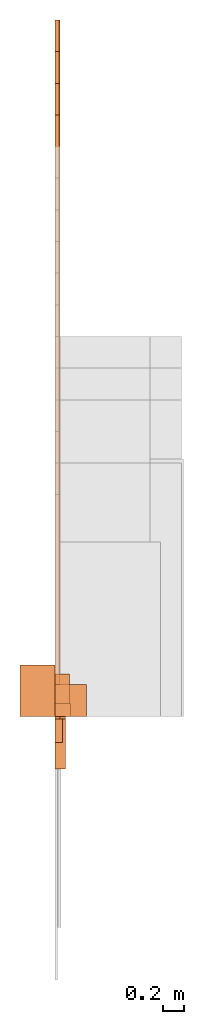
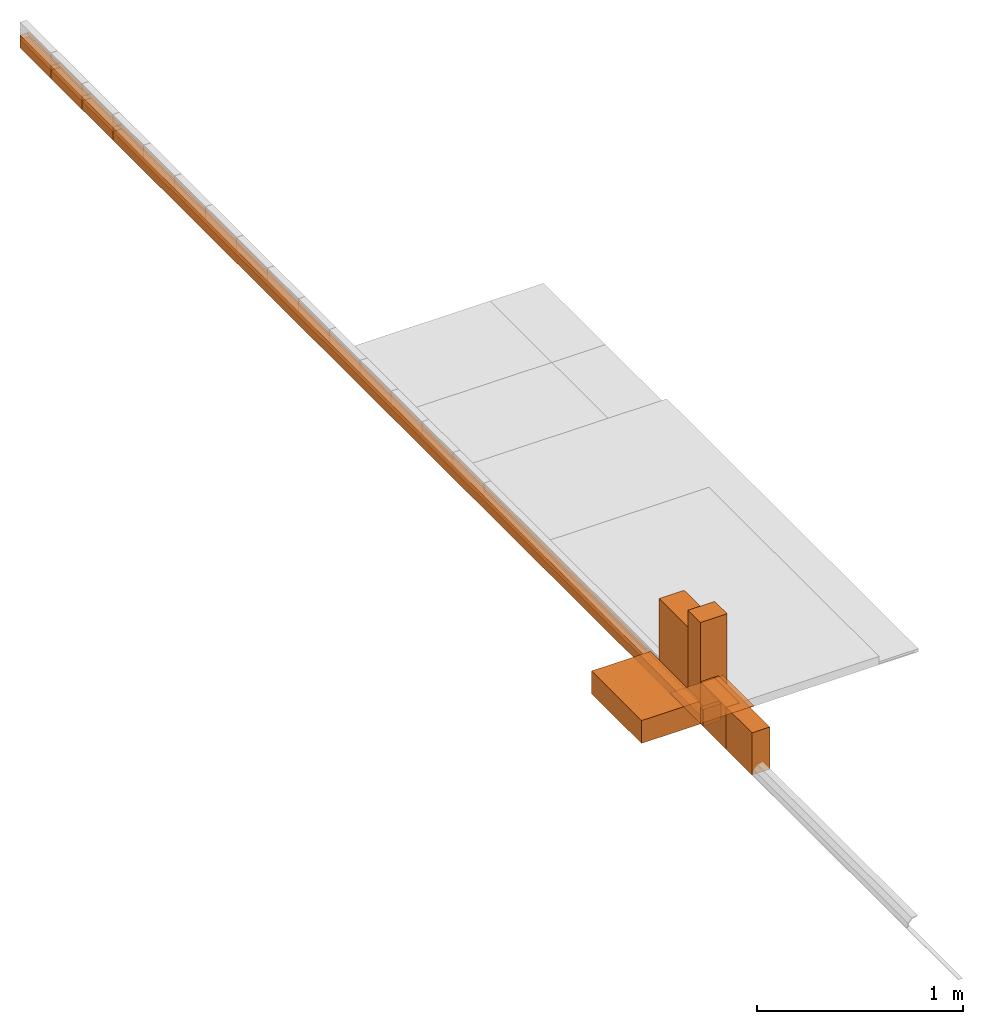
# Not in any storey, part 5 of 5: 22 proxies.
"""IFC4 model written with IfcOpenShell, lengths in metres."""

from ifc_helpers import new_model, entity, si_unit, converted_unit, direction, origin_with_axes, place, context, subcontext, project, faceted_brep, element, save


model = new_model("IFC4")

# Units and contexts
model_context = context("Model", 3, precision=1e-05, world=origin_with_axes(), true_north=direction((0.0, 1.0)))
body_context = subcontext(model_context, "Body", "Model", "MODEL_VIEW")
ifc_project = project(units=[si_unit("LENGTHUNIT", "METRE"), si_unit("AREAUNIT", "SQUARE_METRE"), si_unit("VOLUMEUNIT", "CUBIC_METRE"), converted_unit("PLANEANGLEUNIT", "DEGREE", entity("IfcPlaneAngleMeasure", 0.017453292519943295), si_unit("PLANEANGLEUNIT", "RADIAN"), dimensions=[0, 0, 0, 0, 0, 0, 0])], contexts=[model_context])

# Proxies
proxy_1_placement = place(None, origin_with_axes())
element("IfcBuildingElementProxy", 1, at=proxy_1_placement, Name="Timber 38x76x5700", context=body_context, shape_type="Brep", body=[
    faceted_brep([(0.038, 0.0, 0.0), (0.038, 0.0, 0.076), (0.0, 0.0, 0.076), (0.0, 0.0, 0.0), (0.038, 5.7, 0.0), (0.038, 5.7, 0.076), (0.038, 0.0, 0.076), (0.038, 0.0, 0.0), (0.0, 5.7, 0.0), (0.0, 5.7, 0.076), (0.038, 5.7, 0.076), (0.038, 5.7, 0.0), (0.0, 0.0, 0.0), (0.0, 0.0, 0.076), (0.0, 5.7, 0.076), (0.0, 5.7, 0.0), (0.0, 5.7, 0.0), (0.038, 5.7, 0.0), (0.038, 0.0, 0.0), (0.0, 0.0, 0.0), (0.0, 0.0, 0.076), (0.038, 0.0, 0.076), (0.038, 5.7, 0.076), (0.0, 5.7, 0.076)], [[[0, 1, 2, 3]], [[4, 5, 6, 7]], [[8, 9, 10, 11]], [[12, 13, 14, 15]], [[16, 17, 18, 19]], [[20, 21, 22, 23]]]),
])
proxy_2_placement = place(None, origin_with_axes())
element("IfcBuildingElementProxy", 2, at=proxy_2_placement, Name="Timber 38x76x6000", context=body_context, shape_type="Brep", body=[
    faceted_brep([(0.0, 6.0, 0.0), (0.0, 6.0, 0.076), (0.038, 6.0, 0.076), (0.038, 6.0, 0.0), (0.038, 6.0, 0.0), (0.038, 6.0, 0.076), (0.038, 0.0, 0.076), (0.038, 0.0, 0.0), (0.038, 0.0, 0.0), (0.038, 0.0, 0.076), (0.0, 0.0, 0.076), (0.0, 0.0, 0.0), (0.0, 0.0, 0.0), (0.0, 0.0, 0.076), (0.0, 6.0, 0.076), (0.0, 6.0, 0.0), (0.038, 0.0, 0.0), (0.0, 0.0, 0.0), (0.0, 6.0, 0.0), (0.038, 6.0, 0.0), (0.038, 6.0, 0.076), (0.0, 6.0, 0.076), (0.0, 0.0, 0.076), (0.038, 0.0, 0.076)], [[[0, 1, 2, 3]], [[4, 5, 6, 7]], [[8, 9, 10, 11]], [[12, 13, 14, 15]], [[16, 17, 18, 19]], [[20, 21, 22, 23]]]),
])
proxy_3_placement = place(None, origin_with_axes())
element("IfcBuildingElementProxy", 3, at=proxy_3_placement, Name="Timber 38x76x6300", context=body_context, shape_type="Brep", body=[
    faceted_brep([(0.038, 0.0, 0.0), (0.038, 0.0, 0.076), (0.0, 0.0, 0.076), (0.0, 0.0, 0.0), (0.038, 6.3, 0.0), (0.038, 6.3, 0.076), (0.038, 0.0, 0.076), (0.038, 0.0, 0.0), (0.0, 6.3, 0.0), (0.0, 6.3, 0.076), (0.038, 6.3, 0.076), (0.038, 6.3, 0.0), (0.0, 0.0, 0.0), (0.0, 0.0, 0.076), (0.0, 6.3, 0.076), (0.0, 6.3, 0.0), (0.0, 6.3, 0.0), (0.038, 6.3, 0.0), (0.038, 0.0, 0.0), (0.0, 0.0, 0.0), (0.0, 0.0, 0.076), (0.038, 0.0, 0.076), (0.038, 6.3, 0.076), (0.0, 6.3, 0.076)], [[[0, 1, 2, 3]], [[4, 5, 6, 7]], [[8, 9, 10, 11]], [[12, 13, 14, 15]], [[16, 17, 18, 19]], [[20, 21, 22, 23]]]),
])
proxy_4_placement = place(None, origin_with_axes())
element("IfcBuildingElementProxy", 4, at=proxy_4_placement, Name="Timber 38x76x6600", context=body_context, shape_type="Brep", body=[
    faceted_brep([(0.038, 0.0, 0.0), (0.038, 0.0, 0.076), (0.0, 0.0, 0.076), (0.0, 0.0, 0.0), (0.038, 6.6, 0.0), (0.038, 6.6, 0.076), (0.038, 0.0, 0.076), (0.038, 0.0, 0.0), (0.0, 6.6, 0.0), (0.0, 6.6, 0.076), (0.038, 6.6, 0.076), (0.038, 6.6, 0.0), (0.0, 0.0, 0.0), (0.0, 0.0, 0.076), (0.0, 6.6, 0.076), (0.0, 6.6, 0.0), (0.0, 6.6, 0.0), (0.038, 6.6, 0.0), (0.038, 0.0, 0.0), (0.0, 0.0, 0.0), (0.0, 0.0, 0.076), (0.038, 0.0, 0.076), (0.038, 6.6, 0.076), (0.0, 6.6, 0.076)], [[[0, 1, 2, 3]], [[4, 5, 6, 7]], [[8, 9, 10, 11]], [[12, 13, 14, 15]], [[16, 17, 18, 19]], [[20, 21, 22, 23]]]),
])
proxy_5_placement = place(None, origin_with_axes())
element("IfcBuildingElementProxy", 5, at=proxy_5_placement, Name="Timber 50x50x5700", context=body_context, shape_type="Brep", body=[
    faceted_brep([(0.05, 0.0, 0.0), (0.05, 0.0, 0.05), (0.0, 0.0, 0.05), (0.0, 0.0, 0.0), (0.05, 5.7, 0.0), (0.05, 5.7, 0.05), (0.05, 0.0, 0.05), (0.05, 0.0, 0.0), (0.0, 5.7, 0.0), (0.0, 5.7, 0.05), (0.05, 5.7, 0.05), (0.05, 5.7, 0.0), (0.0, 0.0, 0.0), (0.0, 0.0, 0.05), (0.0, 5.7, 0.05), (0.0, 5.7, 0.0), (0.0, 5.7, 0.0), (0.05, 5.7, 0.0), (0.05, 0.0, 0.0), (0.0, 0.0, 0.0), (0.0, 0.0, 0.05), (0.05, 0.0, 0.05), (0.05, 5.7, 0.05), (0.0, 5.7, 0.05)], [[[0, 1, 2, 3]], [[4, 5, 6, 7]], [[8, 9, 10, 11]], [[12, 13, 14, 15]], [[16, 17, 18, 19]], [[20, 21, 22, 23]]]),
])
proxy_6_placement = place(None, origin_with_axes())
element("IfcBuildingElementProxy", 6, at=proxy_6_placement, Name="Timber 50x50x6000", context=body_context, shape_type="Brep", body=[
    faceted_brep([(0.05, 0.0, 0.0), (0.05, 0.0, 0.05), (0.0, 0.0, 0.05), (0.0, 0.0, 0.0), (0.05, 6.0, 0.0), (0.05, 6.0, 0.05), (0.05, 0.0, 0.05), (0.05, 0.0, 0.0), (0.0, 6.0, 0.0), (0.0, 6.0, 0.05), (0.05, 6.0, 0.05), (0.05, 6.0, 0.0), (0.0, 0.0, 0.0), (0.0, 0.0, 0.05), (0.0, 6.0, 0.05), (0.0, 6.0, 0.0), (0.0, 6.0, 0.0), (0.05, 6.0, 0.0), (0.05, 0.0, 0.0), (0.0, 0.0, 0.0), (0.0, 0.0, 0.05), (0.05, 0.0, 0.05), (0.05, 6.0, 0.05), (0.0, 6.0, 0.05)], [[[0, 1, 2, 3]], [[4, 5, 6, 7]], [[8, 9, 10, 11]], [[12, 13, 14, 15]], [[16, 17, 18, 19]], [[20, 21, 22, 23]]]),
])
proxy_7_placement = place(None, origin_with_axes())
element("IfcBuildingElementProxy", 7, at=proxy_7_placement, Name="Timber 50x50x6300", context=body_context, shape_type="Brep", body=[
    faceted_brep([(0.05, 0.0, 0.0), (0.05, 0.0, 0.05), (0.0, 0.0, 0.05), (0.0, 0.0, 0.0), (0.05, 6.3, 0.0), (0.05, 6.3, 0.05), (0.05, 0.0, 0.05), (0.05, 0.0, 0.0), (0.0, 6.3, 0.0), (0.0, 6.3, 0.05), (0.05, 6.3, 0.05), (0.05, 6.3, 0.0), (0.0, 0.0, 0.0), (0.0, 0.0, 0.05), (0.0, 6.3, 0.05), (0.0, 6.3, 0.0), (0.0, 6.3, 0.0), (0.05, 6.3, 0.0), (0.05, 0.0, 0.0), (0.0, 0.0, 0.0), (0.0, 0.0, 0.05), (0.05, 0.0, 0.05), (0.05, 6.3, 0.05), (0.0, 6.3, 0.05)], [[[0, 1, 2, 3]], [[4, 5, 6, 7]], [[8, 9, 10, 11]], [[12, 13, 14, 15]], [[16, 17, 18, 19]], [[20, 21, 22, 23]]]),
])
proxy_8_placement = place(None, origin_with_axes())
element("IfcBuildingElementProxy", 8, at=proxy_8_placement, Name="Timber 50x50x6600", context=body_context, shape_type="Brep", body=[
    faceted_brep([(0.05, 0.0, 0.0), (0.05, 0.0, 0.05), (0.0, 0.0, 0.05), (0.0, 0.0, 0.0), (0.05, 6.6, 0.0), (0.05, 6.6, 0.05), (0.05, 0.0, 0.05), (0.05, 0.0, 0.0), (0.0, 6.6, 0.0), (0.0, 6.6, 0.05), (0.05, 6.6, 0.05), (0.05, 6.6, 0.0), (0.0, 0.0, 0.0), (0.0, 0.0, 0.05), (0.0, 6.6, 0.05), (0.0, 6.6, 0.0), (0.0, 6.6, 0.0), (0.05, 6.6, 0.0), (0.05, 0.0, 0.0), (0.0, 0.0, 0.0), (0.0, 0.0, 0.05), (0.05, 0.0, 0.05), (0.05, 6.6, 0.05), (0.0, 6.6, 0.05)], [[[0, 1, 2, 3]], [[4, 5, 6, 7]], [[8, 9, 10, 11]], [[12, 13, 14, 15]], [[16, 17, 18, 19]], [[20, 21, 22, 23]]]),
])
proxy_9_placement = place(None, origin_with_axes())
element("IfcBuildingElementProxy", 9, at=proxy_9_placement, Name="Timber 50x76x5700", context=body_context, shape_type="Brep", body=[
    faceted_brep([(0.05, 0.0, 0.0), (0.05, 0.0, 0.076), (0.0, 0.0, 0.076), (0.0, 0.0, 0.0), (0.05, 5.7, 0.0), (0.05, 5.7, 0.076), (0.05, 0.0, 0.076), (0.05, 0.0, 0.0), (0.0, 5.7, 0.0), (0.0, 5.7, 0.076), (0.05, 5.7, 0.076), (0.05, 5.7, 0.0), (0.0, 0.0, 0.0), (0.0, 0.0, 0.076), (0.0, 5.7, 0.076), (0.0, 5.7, 0.0), (0.0, 5.7, 0.0), (0.05, 5.7, 0.0), (0.05, 0.0, 0.0), (0.0, 0.0, 0.0), (0.0, 0.0, 0.076), (0.05, 0.0, 0.076), (0.05, 5.7, 0.076), (0.0, 5.7, 0.076)], [[[0, 1, 2, 3]], [[4, 5, 6, 7]], [[8, 9, 10, 11]], [[12, 13, 14, 15]], [[16, 17, 18, 19]], [[20, 21, 22, 23]]]),
])
proxy_10_placement = place(None, origin_with_axes())
element("IfcBuildingElementProxy", 10, at=proxy_10_placement, Name="Timber 50x76x6000", context=body_context, shape_type="Brep", body=[
    faceted_brep([(0.05, 0.0, 0.0), (0.05, 0.0, 0.076), (0.0, 0.0, 0.076), (0.0, 0.0, 0.0), (0.05, 6.0, 0.0), (0.05, 6.0, 0.076), (0.05, 0.0, 0.076), (0.05, 0.0, 0.0), (0.0, 6.0, 0.0), (0.0, 6.0, 0.076), (0.05, 6.0, 0.076), (0.05, 6.0, 0.0), (0.0, 0.0, 0.0), (0.0, 0.0, 0.076), (0.0, 6.0, 0.076), (0.0, 6.0, 0.0), (0.0, 6.0, 0.0), (0.05, 6.0, 0.0), (0.05, 0.0, 0.0), (0.0, 0.0, 0.0), (0.0, 0.0, 0.076), (0.05, 0.0, 0.076), (0.05, 6.0, 0.076), (0.0, 6.0, 0.076)], [[[0, 1, 2, 3]], [[4, 5, 6, 7]], [[8, 9, 10, 11]], [[12, 13, 14, 15]], [[16, 17, 18, 19]], [[20, 21, 22, 23]]]),
])
proxy_11_placement = place(None, origin_with_axes())
element("IfcBuildingElementProxy", 11, at=proxy_11_placement, Name="Timber 50x76x6300", context=body_context, shape_type="Brep", body=[
    faceted_brep([(0.05, 0.0, 0.0), (0.05, 0.0, 0.076), (0.0, 0.0, 0.076), (0.0, 0.0, 0.0), (0.05, 6.3, 0.0), (0.05, 6.3, 0.076), (0.05, 0.0, 0.076), (0.05, 0.0, 0.0), (0.0, 6.3, 0.0), (0.0, 6.3, 0.076), (0.05, 6.3, 0.076), (0.05, 6.3, 0.0), (0.0, 0.0, 0.0), (0.0, 0.0, 0.076), (0.0, 6.3, 0.076), (0.0, 6.3, 0.0), (0.0, 6.3, 0.0), (0.05, 6.3, 0.0), (0.05, 0.0, 0.0), (0.0, 0.0, 0.0), (0.0, 0.0, 0.076), (0.05, 0.0, 0.076), (0.05, 6.3, 0.076), (0.0, 6.3, 0.076)], [[[0, 1, 2, 3]], [[4, 5, 6, 7]], [[8, 9, 10, 11]], [[12, 13, 14, 15]], [[16, 17, 18, 19]], [[20, 21, 22, 23]]]),
])
proxy_12_placement = place(None, origin_with_axes())
element("IfcBuildingElementProxy", 12, at=proxy_12_placement, Name="Timber 50x76x6600", context=body_context, shape_type="Brep", body=[
    faceted_brep([(0.05, 0.0, 0.0), (0.05, 0.0, 0.076), (0.0, 0.0, 0.076), (0.0, 0.0, 0.0), (0.05, 6.6, 0.0), (0.05, 6.6, 0.076), (0.05, 0.0, 0.076), (0.05, 0.0, 0.0), (0.0, 6.6, 0.0), (0.0, 6.6, 0.076), (0.05, 6.6, 0.076), (0.05, 6.6, 0.0), (0.0, 0.0, 0.0), (0.0, 0.0, 0.076), (0.0, 6.6, 0.076), (0.0, 6.6, 0.0), (0.0, 6.6, 0.0), (0.05, 6.6, 0.0), (0.05, 0.0, 0.0), (0.0, 0.0, 0.0), (0.0, 0.0, 0.076), (0.05, 0.0, 0.076), (0.05, 6.6, 0.076), (0.0, 6.6, 0.076)], [[[0, 1, 2, 3]], [[4, 5, 6, 7]], [[8, 9, 10, 11]], [[12, 13, 14, 15]], [[16, 17, 18, 19]], [[20, 21, 22, 23]]]),
])
proxy_13_placement = place(None, origin_with_axes())
element("IfcBuildingElementProxy", 13, at=proxy_13_placement, Name="300x300x1.6 75no", context=body_context, shape_type="Brep", body=[
    faceted_brep([(0.3, 0.0, 0.0), (0.3, 0.0, 0.0016), (0.0, 0.0, 0.0016), (0.0, 0.0, 0.0), (0.3, 0.3, 0.0), (0.3, 0.3, 0.0016), (0.3, 0.0, 0.0016), (0.3, 0.0, 0.0), (0.0, 0.3, 0.0), (0.0, 0.3, 0.0016), (0.3, 0.3, 0.0016), (0.3, 0.3, 0.0), (0.0, 0.0, 0.0), (0.0, 0.0, 0.0016), (0.0, 0.3, 0.0016), (0.0, 0.3, 0.0), (0.0, 0.3, 0.0), (0.3, 0.3, 0.0), (0.3, 0.0, 0.0), (0.0, 0.0, 0.0), (0.0, 0.0, 0.0016), (0.3, 0.0, 0.0016), (0.3, 0.3, 0.0016), (0.0, 0.3, 0.0016)], [[[0, 1, 2, 3]], [[4, 5, 6, 7]], [[8, 9, 10, 11]], [[12, 13, 14, 15]], [[16, 17, 18, 19]], [[20, 21, 22, 23]]]),
])
proxy_14_placement = place(None, origin_with_axes())
element("IfcBuildingElementProxy", 14, at=proxy_14_placement, Name="300x300x2 50no", context=body_context, shape_type="Brep", body=[
    faceted_brep([(0.3, 0.0, 0.0), (0.3, 0.0, 0.002), (0.0, 0.0, 0.002), (0.0, 0.0, 0.0), (0.3, 0.3, 0.0), (0.3, 0.3, 0.002), (0.3, 0.0, 0.002), (0.3, 0.0, 0.0), (0.0, 0.3, 0.0), (0.0, 0.3, 0.002), (0.3, 0.3, 0.002), (0.3, 0.3, 0.0), (0.0, 0.0, 0.0), (0.0, 0.0, 0.002), (0.0, 0.3, 0.002), (0.0, 0.3, 0.0), (0.0, 0.3, 0.0), (0.3, 0.3, 0.0), (0.3, 0.0, 0.0), (0.0, 0.0, 0.0), (0.0, 0.0, 0.002), (0.3, 0.0, 0.002), (0.3, 0.3, 0.002), (0.0, 0.3, 0.002)], [[[0, 1, 2, 3]], [[4, 5, 6, 7]], [[8, 9, 10, 11]], [[12, 13, 14, 15]], [[16, 17, 18, 19]], [[20, 21, 22, 23]]]),
])
proxy_15_placement = place(None, origin_with_axes())
element("IfcBuildingElementProxy", 15, at=proxy_15_placement, Name="300x300x2.5 50no", context=body_context, shape_type="Brep", body=[
    faceted_brep([(0.3, 0.0, 0.0), (0.3, 0.0, 0.0025), (0.0, 0.0, 0.0025), (0.0, 0.0, 0.0), (0.3, 0.3, 0.0), (0.3, 0.3, 0.0025), (0.3, 0.0, 0.0025), (0.3, 0.0, 0.0), (0.0, 0.3, 0.0), (0.0, 0.3, 0.0025), (0.3, 0.3, 0.0025), (0.3, 0.3, 0.0), (0.0, 0.0, 0.0), (0.0, 0.0, 0.0025), (0.0, 0.3, 0.0025), (0.0, 0.3, 0.0), (0.0, 0.3, 0.0), (0.3, 0.3, 0.0), (0.3, 0.0, 0.0), (0.0, 0.0, 0.0), (0.0, 0.0, 0.0025), (0.3, 0.0, 0.0025), (0.3, 0.3, 0.0025), (0.0, 0.3, 0.0025)], [[[0, 1, 2, 3]], [[4, 5, 6, 7]], [[8, 9, 10, 11]], [[12, 13, 14, 15]], [[16, 17, 18, 19]], [[20, 21, 22, 23]]]),
])
proxy_16_placement = place(None, origin_with_axes())
element("IfcBuildingElementProxy", 16, at=proxy_16_placement, Name="5KV", context=body_context, shape_type="Brep", body=[
    faceted_brep([(0.0, 0.0, 0.0), (0.0, 0.0, 0.135), (-0.33, 0.0, 0.135), (-0.33, 0.0, 0.0), (-0.33, 0.0, 0.0), (-0.33, 0.0, 0.135), (-0.33, 0.485, 0.135), (-0.33, 0.485, 0.0), (-0.33, 0.485, 0.0), (-0.33, 0.485, 0.135), (0.0, 0.485, 0.135), (0.0, 0.485, 0.0), (0.0, 0.485, 0.0), (0.0, 0.485, 0.135), (0.0, 0.0, 0.135), (0.0, 0.0, 0.0), (-0.33, 0.485, 0.0), (0.0, 0.485, 0.0), (0.0, 0.0, 0.0), (-0.33, 0.0, 0.0), (-0.33, 0.0, 0.135), (0.0, 0.0, 0.135), (0.0, 0.485, 0.135), (-0.33, 0.485, 0.135)], [[[0, 1, 2, 3]], [[4, 5, 6, 7]], [[8, 9, 10, 11]], [[12, 13, 14, 15]], [[16, 17, 18, 19]], [[20, 21, 22, 23]]]),
])
proxy_17_placement = place(None, origin_with_axes())
element("IfcBuildingElementProxy", 17, at=proxy_17_placement, Name="6way mini DB", context=body_context, shape_type="Brep", body=[
    faceted_brep([(0.1, 0.0, 0.0), (0.1, -0.5, 0.0), (0.0, -0.5, 0.0), (0.0, 0.0, 0.0), (0.1, 0.0, 0.25), (0.1, -0.5, 0.25), (0.1, -0.5, 0.0), (0.1, 0.0, 0.0), (0.0, 0.0, 0.25), (0.0, -0.5, 0.25), (0.1, -0.5, 0.25), (0.1, 0.0, 0.25), (0.0, 0.0, 0.0), (0.0, -0.5, 0.0), (0.0, -0.5, 0.25), (0.0, 0.0, 0.25), (0.1, 0.0, 0.0), (0.0, 0.0, 0.0), (0.0, 0.0, 0.25), (0.1, 0.0, 0.25), (0.1, -0.5, 0.25), (0.0, -0.5, 0.25), (0.0, -0.5, 0.0), (0.1, -0.5, 0.0)], [[[0, 1, 2, 3]], [[4, 5, 6, 7]], [[8, 9, 10, 11]], [[12, 13, 14, 15]], [[16, 17, 18, 19]], [[20, 21, 22, 23]]]),
])
proxy_18_placement = place(None, origin_with_axes())
element("IfcBuildingElementProxy", 18, at=proxy_18_placement, context=body_context, shape_type="Brep", body=[
    faceted_brep([(0.14, 0.0, 0.0), (0.14, 0.0, 0.5), (0.0, 0.0, 0.5), (0.0, 0.0, 0.0), (0.14, 0.4, 0.0), (0.14, 0.4, 0.5), (0.14, 0.0, 0.5), (0.14, 0.0, 0.0), (0.0, 0.4, 0.0), (0.0, 0.4, 0.5), (0.14, 0.4, 0.5), (0.14, 0.4, 0.0), (0.0, 0.0, 0.0), (0.0, 0.0, 0.5), (0.0, 0.4, 0.5), (0.0, 0.4, 0.0), (0.0, 0.4, 0.0), (0.14, 0.4, 0.0), (0.14, 0.0, 0.0), (0.0, 0.0, 0.0), (0.0, 0.0, 0.5), (0.14, 0.0, 0.5), (0.14, 0.4, 0.5), (0.0, 0.4, 0.5)], [[[0, 1, 2, 3]], [[4, 5, 6, 7]], [[8, 9, 10, 11]], [[12, 13, 14, 15]], [[16, 17, 18, 19]], [[20, 21, 22, 23]]]),
])
proxy_19_placement = place(None, origin_with_axes())
element("IfcBuildingElementProxy", 19, at=proxy_19_placement, Name="Double plug", context=body_context, shape_type="Brep", body=[
    faceted_brep([(0.1, 0.0, 0.0), (0.1, -0.025, 0.0), (0.0, -0.025, 0.0), (0.0, 0.0, 0.0), (0.1, 0.0, 0.1), (0.1, -0.025, 0.1), (0.1, -0.025, 0.0), (0.1, 0.0, 0.0), (0.0, 0.0, 0.1), (0.0, -0.025, 0.1), (0.1, -0.025, 0.1), (0.1, 0.0, 0.1), (0.0, 0.0, 0.0), (0.0, -0.025, 0.0), (0.0, -0.025, 0.1), (0.0, 0.0, 0.1), (0.1, 0.0, 0.0), (0.0, 0.0, 0.0), (0.0, 0.0, 0.1), (0.1, 0.0, 0.1), (0.1, -0.025, 0.1), (0.0, -0.025, 0.1), (0.0, -0.025, 0.0), (0.1, -0.025, 0.0)], [[[0, 1, 2, 3]], [[4, 5, 6, 7]], [[8, 9, 10, 11]], [[12, 13, 14, 15]], [[16, 17, 18, 19]], [[20, 21, 22, 23]]]),
])
proxy_20_placement = place(None, origin_with_axes())
element("IfcBuildingElementProxy", 20, at=proxy_20_placement, Name="Light switch", context=body_context, shape_type="Brep", body=[
    faceted_brep([(0.05, 0.0, 0.0), (0.05, -0.025, 0.0), (0.0, -0.025, 0.0), (0.0, 0.0, 0.0), (0.05, 0.0, 0.1), (0.05, -0.025, 0.1), (0.05, -0.025, 0.0), (0.05, 0.0, 0.0), (0.0, 0.0, 0.1), (0.0, -0.025, 0.1), (0.05, -0.025, 0.1), (0.05, 0.0, 0.1), (0.0, 0.0, 0.0), (0.0, -0.025, 0.0), (0.0, -0.025, 0.1), (0.0, 0.0, 0.1), (0.05, 0.0, 0.0), (0.0, 0.0, 0.0), (0.0, 0.0, 0.1), (0.05, 0.0, 0.1), (0.05, -0.025, 0.1), (0.0, -0.025, 0.1), (0.0, -0.025, 0.0), (0.05, -0.025, 0.0)], [[[0, 1, 2, 3]], [[4, 5, 6, 7]], [[8, 9, 10, 11]], [[12, 13, 14, 15]], [[16, 17, 18, 19]], [[20, 21, 22, 23]]]),
])
proxy_21_placement = place(None, origin_with_axes())
element("IfcBuildingElementProxy", 21, at=proxy_21_placement, Name="Ceiling Light 600mm", context=body_context, shape_type="Brep", body=[
    faceted_brep([(0.15, 0.0, 0.0), (0.15, 0.0, 0.6), (0.0, 0.0, 0.6), (0.0, 0.0, 0.0), (0.15, 0.121, 0.0), (0.15, 0.121, 0.6), (0.15, 0.0, 0.6), (0.15, 0.0, 0.0), (0.0, 0.121, 0.0), (0.0, 0.121, 0.6), (0.15, 0.121, 0.6), (0.15, 0.121, 0.0), (0.0, 0.0, 0.0), (0.0, 0.0, 0.6), (0.0, 0.121, 0.6), (0.0, 0.121, 0.0), (0.0, 0.121, 0.0), (0.15, 0.121, 0.0), (0.15, 0.0, 0.0), (0.0, 0.0, 0.0), (0.0, 0.0, 0.6), (0.15, 0.0, 0.6), (0.15, 0.121, 0.6), (0.0, 0.121, 0.6)], [[[0, 1, 2, 3]], [[4, 5, 6, 7]], [[8, 9, 10, 11]], [[12, 13, 14, 15]], [[16, 17, 18, 19]], [[20, 21, 22, 23]]]),
])
proxy_22_placement = place(None, origin_with_axes())
element("IfcBuildingElementProxy", 22, at=proxy_22_placement, Name="Outside light", context=body_context, shape_type="Brep", body=[
    faceted_brep([(0.075, 0.0, 0.0), (0.075, -0.25, 0.0), (0.0, -0.25, 0.0), (0.0, 0.0, 0.0), (0.075, 0.0, 0.25), (0.075, -0.25, 0.25), (0.075, -0.25, 0.0), (0.075, 0.0, 0.0), (0.0, 0.0, 0.25), (0.0, -0.25, 0.25), (0.075, -0.25, 0.25), (0.075, 0.0, 0.25), (0.0, 0.0, 0.0), (0.0, -0.25, 0.0), (0.0, -0.25, 0.25), (0.0, 0.0, 0.25), (0.075, 0.0, 0.0), (0.0, 0.0, 0.0), (0.0, 0.0, 0.25), (0.075, 0.0, 0.25), (0.075, -0.25, 0.25), (0.0, -0.25, 0.25), (0.0, -0.25, 0.0), (0.075, -0.25, 0.0)], [[[0, 1, 2, 3]], [[4, 5, 6, 7]], [[8, 9, 10, 11]], [[12, 13, 14, 15]], [[16, 17, 18, 19]], [[20, 21, 22, 23]]]),
])

save(model, "model.ifc")
